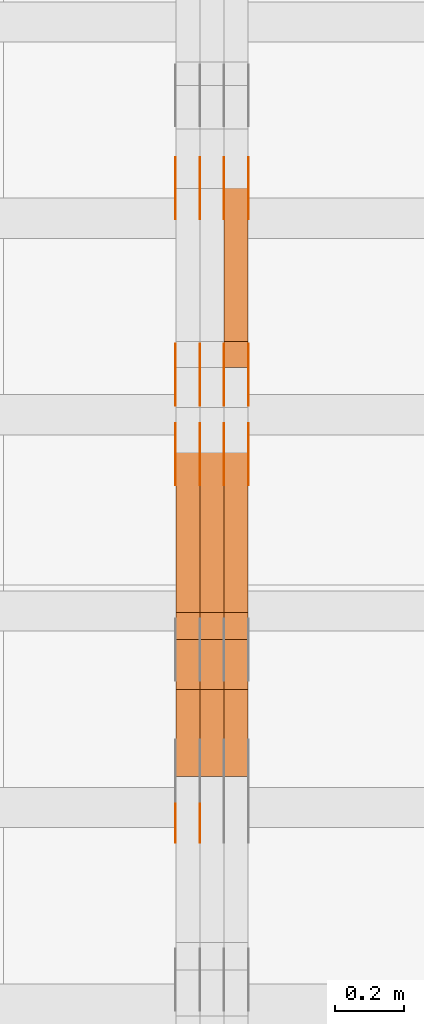
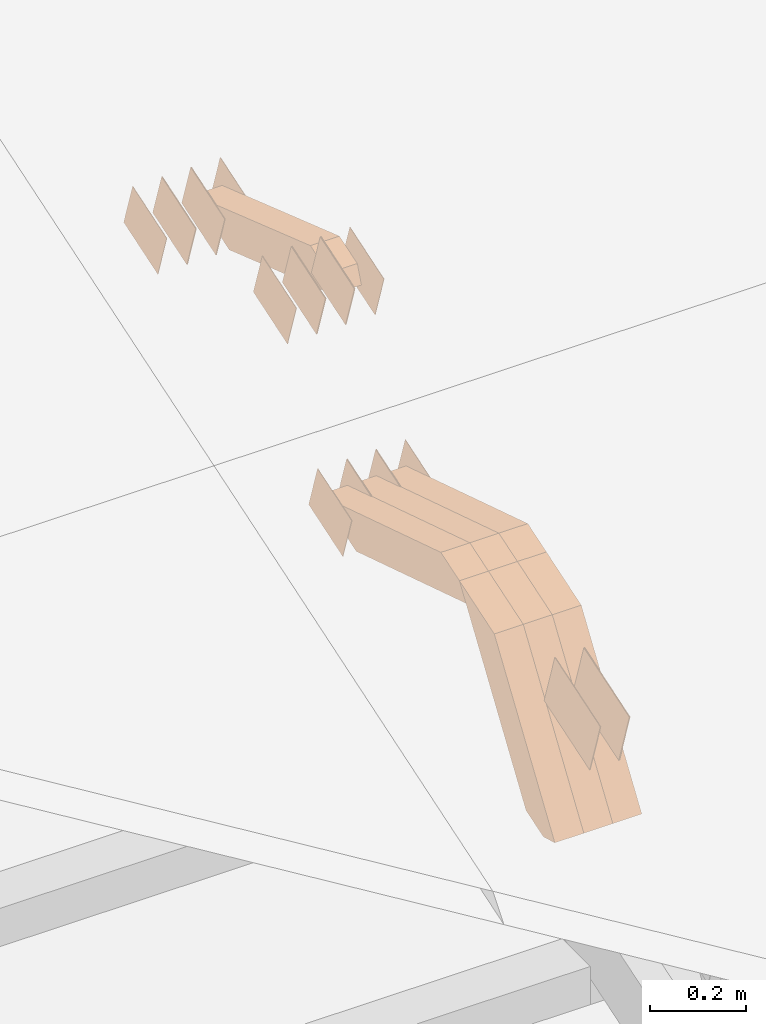
# One storey, part 250 of 385: 28 proxies.
"""IFC2X3 building model written with IfcOpenShell, lengths in millimetres."""

from ifc_helpers import new_model, entity, si_unit, converted_unit, derived_unit, direction, frame, origin, place, context, subcontext, project, spatial, polyline, outline, extrude, source, transform, mapped, material, type_object, type_shapes, element, save


model = new_model("IFC2X3")

# Units and contexts
model_context = context("Model", 3, precision=0.01, world=origin(), true_north=direction((6.12303176911189e-17, 1.0)))
body_context = subcontext(model_context, "Body", "Model", "MODEL_VIEW")
ifc_project = project(units=[si_unit("LENGTHUNIT", "METRE", prefix="MILLI"), si_unit("AREAUNIT", "SQUARE_METRE"), si_unit("VOLUMEUNIT", "CUBIC_METRE"), converted_unit("PLANEANGLEUNIT", "DEGREE", entity("IfcRatioMeasure", 0.0174532925199433), si_unit("PLANEANGLEUNIT", "RADIAN"), dimensions=[0, 0, 0, 0, 0, 0, 0]), si_unit("MASSUNIT", "GRAM", prefix="KILO"), derived_unit("MASSDENSITYUNIT", [(si_unit("MASSUNIT", "GRAM", prefix="KILO"), 1), (si_unit("LENGTHUNIT", "METRE"), -3)]), si_unit("TIMEUNIT", "SECOND"), si_unit("FREQUENCYUNIT", "HERTZ"), si_unit("THERMODYNAMICTEMPERATUREUNIT", "DEGREE_CELSIUS"), derived_unit("THERMALTRANSMITTANCEUNIT", [(si_unit("MASSUNIT", "GRAM", prefix="KILO"), 1), (si_unit("THERMODYNAMICTEMPERATUREUNIT", "KELVIN"), -1), (si_unit("TIMEUNIT", "SECOND"), -3)]), derived_unit("VOLUMETRICFLOWRATEUNIT", [(si_unit("LENGTHUNIT", "METRE"), 3), (si_unit("TIMEUNIT", "SECOND"), -1)]), si_unit("ELECTRICCURRENTUNIT", "AMPERE"), si_unit("ELECTRICVOLTAGEUNIT", "VOLT"), si_unit("POWERUNIT", "WATT"), si_unit("FORCEUNIT", "NEWTON", prefix="KILO"), si_unit("ILLUMINANCEUNIT", "LUX"), si_unit("LUMINOUSFLUXUNIT", "LUMEN"), si_unit("LUMINOUSINTENSITYUNIT", "CANDELA"), derived_unit("USERDEFINED", [(si_unit("MASSUNIT", "GRAM", prefix="KILO"), -1), (si_unit("LENGTHUNIT", "METRE"), -2), (si_unit("TIMEUNIT", "SECOND"), 3), (si_unit("LUMINOUSFLUXUNIT", "LUMEN"), 1)]), derived_unit("LINEARVELOCITYUNIT", [(si_unit("LENGTHUNIT", "METRE"), 1), (si_unit("TIMEUNIT", "SECOND"), -1)]), si_unit("PRESSUREUNIT", "PASCAL"), derived_unit("USERDEFINED", [(si_unit("LENGTHUNIT", "METRE"), -2), (si_unit("MASSUNIT", "GRAM", prefix="KILO"), 1), (si_unit("TIMEUNIT", "SECOND"), -2)])], contexts=[model_context])

# Site, building, storey
site_placement = place(None, origin())
site = spatial("IfcSite", under=ifc_project, at=site_placement, CompositionType="ELEMENT")
building_placement = place(site_placement, origin())
building = spatial("IfcBuilding", under=site, at=building_placement, CompositionType="ELEMENT")
storey_placement = place(building_placement, origin())
storey = spatial("IfcBuildingStorey", under=building, at=storey_placement, Name="Default", CompositionType="ELEMENT", Elevation=0.0)

# Proxies
ifc_material_1 = material(Name="IfcSurfaceStyle #448454")
building_element_proxy_type_1 = type_object("IfcBuildingElementProxyType", PredefinedType="NOTDEFINED", material=ifc_material_1)
shared_shape_1 = source(origin(), body_context, "Body", "SweptSolid", [
    extrude(outline(polyline([(-74.9998754286198, -60.0000016373433), (74.9998605591145, -60.0000016373433), (74.999875428618, 60.0000016373433), (-74.9998605591127, 60.0000016373433), (-74.9998754286198, -60.0000016373433)])), frame((75.0007059026038, 60.000210935219, 0.0), z_axis=(0.0, 0.0, 1.0), x_axis=(-1.0, 0.0, 0.0)), (0.0, 0.0, 1.0), 1.3),
])
type_shapes(building_element_proxy_type_1, [shared_shape_1])
proxy_1_placement = place(building_placement, frame((36386.3, 6760.15341914203, 1372.60670336718), z_axis=(-1.0, 0.0, 0.0), x_axis=(0.0, 0.951056516295124, 0.309016994375039)))
element("IfcBuildingElementProxy", 1, at=proxy_1_placement, inside=storey, type_object=building_element_proxy_type_1, material=ifc_material_1, context=body_context, shape_type="MappedRepresentation", body=[
    mapped(shared_shape_1, transform((0.0, 0.0, 0.0), scale=1.0)),
])
ifc_material_2 = material(Name="IfcSurfaceStyle #448397")
building_element_proxy_type_2 = type_object("IfcBuildingElementProxyType", PredefinedType="NOTDEFINED", material=ifc_material_2)
shared_shape_2 = source(origin(), body_context, "Body", "SweptSolid", [
    extrude(outline(polyline([(-74.9998754286198, -60.0000016373433), (74.9998605591145, -60.0000016373433), (74.999875428618, 60.0000016373433), (-74.9998605591127, 60.0000016373433), (-74.9998754286198, -60.0000016373433)])), frame((75.0007059026038, 60.000210935219, 0.0), z_axis=(0.0, 0.0, 1.0), x_axis=(-1.0, 0.0, 0.0)), (0.0, 0.0, 1.0), 1.3),
])
type_shapes(building_element_proxy_type_2, [shared_shape_2])
proxy_2_placement = place(building_placement, frame((36315.0, 6760.15341914203, 1372.60670336718), z_axis=(-1.0, 0.0, 0.0), x_axis=(0.0, 0.951056516295124, 0.309016994375039)))
element("IfcBuildingElementProxy", 2, at=proxy_2_placement, inside=storey, type_object=building_element_proxy_type_2, material=ifc_material_2, context=body_context, shape_type="MappedRepresentation", body=[
    mapped(shared_shape_2, transform((0.0, 0.0, 0.0), scale=1.0)),
])
ifc_material_3 = material(Name="IfcSurfaceStyle #448340")
building_element_proxy_type_3 = type_object("IfcBuildingElementProxyType", PredefinedType="NOTDEFINED", material=ifc_material_3)
shared_shape_3 = source(origin(), body_context, "Body", "SweptSolid", [
    extrude(outline(polyline([(-74.9998754286198, -60.0000016373433), (74.9998605591145, -60.0000016373433), (74.999875428618, 60.0000016373433), (-74.9998605591127, 60.0000016373433), (-74.9998754286198, -60.0000016373433)])), frame((75.0007059026038, 60.000210935219, 0.0), z_axis=(0.0, 0.0, 1.0), x_axis=(-1.0, 0.0, 0.0)), (0.0, 0.0, 1.0), 1.3),
])
type_shapes(building_element_proxy_type_3, [shared_shape_3])
proxy_3_placement = place(building_placement, frame((36316.3, 6760.15341914203, 1372.60670336718), z_axis=(-1.0, 0.0, 0.0), x_axis=(0.0, 0.951056516295124, 0.309016994375039)))
element("IfcBuildingElementProxy", 3, at=proxy_3_placement, inside=storey, type_object=building_element_proxy_type_3, material=ifc_material_3, context=body_context, shape_type="MappedRepresentation", body=[
    mapped(shared_shape_3, transform((0.0, 0.0, 0.0), scale=1.0)),
])
ifc_material_4 = material(Name="IfcSurfaceStyle #448283")
building_element_proxy_type_4 = type_object("IfcBuildingElementProxyType", PredefinedType="NOTDEFINED", material=ifc_material_4)
shared_shape_4 = source(origin(), body_context, "Body", "SweptSolid", [
    extrude(outline(polyline([(-74.9998754286198, -60.0000016373433), (74.9998605591145, -60.0000016373433), (74.999875428618, 60.0000016373433), (-74.9998605591127, 60.0000016373433), (-74.9998754286198, -60.0000016373433)])), frame((75.0007059026038, 60.000210935219, 0.0), z_axis=(0.0, 0.0, 1.0), x_axis=(-1.0, 0.0, 0.0)), (0.0, 0.0, 1.0), 1.29999999999999),
])
type_shapes(building_element_proxy_type_4, [shared_shape_4])
proxy_4_placement = place(building_placement, frame((36245.0, 6760.15341914203, 1372.60670336718), z_axis=(-1.0, 0.0, 0.0), x_axis=(0.0, 0.951056516295124, 0.309016994375039)))
element("IfcBuildingElementProxy", 4, at=proxy_4_placement, inside=storey, type_object=building_element_proxy_type_4, material=ifc_material_4, context=body_context, shape_type="MappedRepresentation", body=[
    mapped(shared_shape_4, transform((0.0, 0.0, 0.0), scale=1.0)),
])
ifc_material_5 = material(Name="IfcSurfaceStyle #448226")
building_element_proxy_type_5 = type_object("IfcBuildingElementProxyType", PredefinedType="NOTDEFINED", material=ifc_material_5)
shared_shape_5 = source(origin(), body_context, "Body", "SweptSolid", [
    extrude(outline(polyline([(-74.9998754286198, -60.0000016373433), (74.9998605591145, -60.0000016373433), (74.999875428618, 60.0000016373433), (-74.9998605591127, 60.0000016373433), (-74.9998754286198, -60.0000016373433)])), frame((75.0007059026038, 60.000210935219, 0.0), z_axis=(0.0, 0.0, 1.0), x_axis=(-1.0, 0.0, 0.0)), (0.0, 0.0, 1.0), 1.29999999999999),
])
type_shapes(building_element_proxy_type_5, [shared_shape_5])
proxy_5_placement = place(building_placement, frame((36246.3, 6760.15341914203, 1372.60670336718), z_axis=(-1.0, 0.0, 0.0), x_axis=(0.0, 0.951056516295124, 0.309016994375039)))
element("IfcBuildingElementProxy", 5, at=proxy_5_placement, inside=storey, type_object=building_element_proxy_type_5, material=ifc_material_5, context=body_context, shape_type="MappedRepresentation", body=[
    mapped(shared_shape_5, transform((0.0, 0.0, 0.0), scale=1.0)),
])
ifc_material_6 = material(Name="IfcSurfaceStyle #448169")
building_element_proxy_type_6 = type_object("IfcBuildingElementProxyType", PredefinedType="NOTDEFINED", material=ifc_material_6)
shared_shape_6 = source(origin(), body_context, "Body", "SweptSolid", [
    extrude(outline(polyline([(-74.9998754286198, -60.0000016373433), (74.9998605591145, -60.0000016373433), (74.999875428618, 60.0000016373433), (-74.9998605591127, 60.0000016373433), (-74.9998754286198, -60.0000016373433)])), frame((75.0007059026038, 60.000210935219, 0.0), z_axis=(0.0, 0.0, 1.0), x_axis=(-1.0, 0.0, 0.0)), (0.0, 0.0, 1.0), 1.29999999999999),
])
type_shapes(building_element_proxy_type_6, [shared_shape_6])
proxy_6_placement = place(building_placement, frame((36175.0, 6760.15341914203, 1372.60670336718), z_axis=(-1.0, 0.0, 0.0), x_axis=(0.0, 0.951056516295124, 0.309016994375039)))
element("IfcBuildingElementProxy", 6, at=proxy_6_placement, inside=storey, type_object=building_element_proxy_type_6, material=ifc_material_6, context=body_context, shape_type="MappedRepresentation", body=[
    mapped(shared_shape_6, transform((0.0, 0.0, 0.0), scale=1.0)),
])
ifc_material_7 = material(Name="IfcSurfaceStyle #442298")
building_element_proxy_type_7 = type_object("IfcBuildingElementProxyType", PredefinedType="NOTDEFINED", material=ifc_material_7)
shared_shape_7 = source(origin(), body_context, "Body", "SweptSolid", [
    extrude(outline(polyline([(-74.9998801438441, -60.0000306612856), (74.9998747047876, -60.0000306612856), (74.9998707133936, 60.0000306612856), (-74.9998652743371, 60.0000306612856), (-74.9998801438441, -60.0000306612856)])), frame((75.0000206139493, 60.0000306612856, 0.0), z_axis=(0.0, 0.0, 1.0), x_axis=(-1.0, 0.0, 0.0)), (0.0, 0.0, 1.0), 1.3),
])
type_shapes(building_element_proxy_type_7, [shared_shape_7])
proxy_7_placement = place(building_placement, frame((36386.3, 5987.08381858242, 1121.42116774683), z_axis=(-1.0, 0.0, 0.0), x_axis=(0.0, 0.951056516295124, 0.309016994375039)))
element("IfcBuildingElementProxy", 7, at=proxy_7_placement, inside=storey, type_object=building_element_proxy_type_7, material=ifc_material_7, context=body_context, shape_type="MappedRepresentation", body=[
    mapped(shared_shape_7, transform((0.0, 0.0, 0.0), scale=1.0)),
])
ifc_material_8 = material(Name="IfcSurfaceStyle #442241")
building_element_proxy_type_8 = type_object("IfcBuildingElementProxyType", PredefinedType="NOTDEFINED", material=ifc_material_8)
shared_shape_8 = source(origin(), body_context, "Body", "SweptSolid", [
    extrude(outline(polyline([(-74.9998801438441, -60.0000306612856), (74.9998747047876, -60.0000306612856), (74.9998707133936, 60.0000306612856), (-74.9998652743371, 60.0000306612856), (-74.9998801438441, -60.0000306612856)])), frame((75.0000206139493, 60.0000306612856, 0.0), z_axis=(0.0, 0.0, 1.0), x_axis=(-1.0, 0.0, 0.0)), (0.0, 0.0, 1.0), 1.3),
])
type_shapes(building_element_proxy_type_8, [shared_shape_8])
proxy_8_placement = place(building_placement, frame((36315.0, 5987.08381858242, 1121.42116774683), z_axis=(-1.0, 0.0, 0.0), x_axis=(0.0, 0.951056516295124, 0.309016994375039)))
element("IfcBuildingElementProxy", 8, at=proxy_8_placement, inside=storey, type_object=building_element_proxy_type_8, material=ifc_material_8, context=body_context, shape_type="MappedRepresentation", body=[
    mapped(shared_shape_8, transform((0.0, 0.0, 0.0), scale=1.0)),
])
ifc_material_9 = material(Name="IfcSurfaceStyle #442184")
building_element_proxy_type_9 = type_object("IfcBuildingElementProxyType", PredefinedType="NOTDEFINED", material=ifc_material_9)
shared_shape_9 = source(origin(), body_context, "Body", "SweptSolid", [
    extrude(outline(polyline([(-74.9998801438441, -60.0000306612856), (74.9998747047876, -60.0000306612856), (74.9998707133936, 60.0000306612856), (-74.9998652743371, 60.0000306612856), (-74.9998801438441, -60.0000306612856)])), frame((75.0000206139493, 60.0000306612856, 0.0), z_axis=(0.0, 0.0, 1.0), x_axis=(-1.0, 0.0, 0.0)), (0.0, 0.0, 1.0), 1.3),
])
type_shapes(building_element_proxy_type_9, [shared_shape_9])
proxy_9_placement = place(building_placement, frame((36316.3, 5987.08381858242, 1121.42116774683), z_axis=(-1.0, 0.0, 0.0), x_axis=(0.0, 0.951056516295124, 0.309016994375039)))
element("IfcBuildingElementProxy", 9, at=proxy_9_placement, inside=storey, type_object=building_element_proxy_type_9, material=ifc_material_9, context=body_context, shape_type="MappedRepresentation", body=[
    mapped(shared_shape_9, transform((0.0, 0.0, 0.0), scale=1.0)),
])
ifc_material_10 = material(Name="IfcSurfaceStyle #442127")
building_element_proxy_type_10 = type_object("IfcBuildingElementProxyType", PredefinedType="NOTDEFINED", material=ifc_material_10)
shared_shape_10 = source(origin(), body_context, "Body", "SweptSolid", [
    extrude(outline(polyline([(-74.9998801438441, -60.0000306612856), (74.9998747047876, -60.0000306612856), (74.9998707133936, 60.0000306612856), (-74.9998652743371, 60.0000306612856), (-74.9998801438441, -60.0000306612856)])), frame((75.0000206139493, 60.0000306612856, 0.0), z_axis=(0.0, 0.0, 1.0), x_axis=(-1.0, 0.0, 0.0)), (0.0, 0.0, 1.0), 1.29999999999999),
])
type_shapes(building_element_proxy_type_10, [shared_shape_10])
proxy_10_placement = place(building_placement, frame((36245.0, 5987.08381858242, 1121.42116774683), z_axis=(-1.0, 0.0, 0.0), x_axis=(0.0, 0.951056516295124, 0.309016994375039)))
element("IfcBuildingElementProxy", 10, at=proxy_10_placement, inside=storey, type_object=building_element_proxy_type_10, material=ifc_material_10, context=body_context, shape_type="MappedRepresentation", body=[
    mapped(shared_shape_10, transform((0.0, 0.0, 0.0), scale=1.0)),
])
ifc_material_11 = material(Name="IfcSurfaceStyle #442070")
building_element_proxy_type_11 = type_object("IfcBuildingElementProxyType", PredefinedType="NOTDEFINED", material=ifc_material_11)
shared_shape_11 = source(origin(), body_context, "Body", "SweptSolid", [
    extrude(outline(polyline([(-74.9998801438441, -60.0000306612856), (74.9998747047876, -60.0000306612856), (74.9998707133936, 60.0000306612856), (-74.9998652743371, 60.0000306612856), (-74.9998801438441, -60.0000306612856)])), frame((75.0000206139493, 60.0000306612856, 0.0), z_axis=(0.0, 0.0, 1.0), x_axis=(-1.0, 0.0, 0.0)), (0.0, 0.0, 1.0), 1.29999999999999),
])
type_shapes(building_element_proxy_type_11, [shared_shape_11])
proxy_11_placement = place(building_placement, frame((36246.3, 5987.08381858242, 1121.42116774683), z_axis=(-1.0, 0.0, 0.0), x_axis=(0.0, 0.951056516295124, 0.309016994375039)))
element("IfcBuildingElementProxy", 11, at=proxy_11_placement, inside=storey, type_object=building_element_proxy_type_11, material=ifc_material_11, context=body_context, shape_type="MappedRepresentation", body=[
    mapped(shared_shape_11, transform((0.0, 0.0, 0.0), scale=1.0)),
])
ifc_material_12 = material(Name="IfcSurfaceStyle #442013")
building_element_proxy_type_12 = type_object("IfcBuildingElementProxyType", PredefinedType="NOTDEFINED", material=ifc_material_12)
shared_shape_12 = source(origin(), body_context, "Body", "SweptSolid", [
    extrude(outline(polyline([(-74.9998801438441, -60.0000306612856), (74.9998747047876, -60.0000306612856), (74.9998707133936, 60.0000306612856), (-74.9998652743371, 60.0000306612856), (-74.9998801438441, -60.0000306612856)])), frame((75.0000206139493, 60.0000306612856, 0.0), z_axis=(0.0, 0.0, 1.0), x_axis=(-1.0, 0.0, 0.0)), (0.0, 0.0, 1.0), 1.29999999999999),
])
type_shapes(building_element_proxy_type_12, [shared_shape_12])
proxy_12_placement = place(building_placement, frame((36175.0, 5987.08381858242, 1121.42116774683), z_axis=(-1.0, 0.0, 0.0), x_axis=(0.0, 0.951056516295124, 0.309016994375039)))
element("IfcBuildingElementProxy", 12, at=proxy_12_placement, inside=storey, type_object=building_element_proxy_type_12, material=ifc_material_12, context=body_context, shape_type="MappedRepresentation", body=[
    mapped(shared_shape_12, transform((0.0, 0.0, 0.0), scale=1.0)),
])
ifc_material_13 = material(Name="IfcSurfaceStyle #437852")
building_element_proxy_type_13 = type_object("IfcBuildingElementProxyType", PredefinedType="NOTDEFINED", material=ifc_material_13)
shared_shape_13 = source(origin(), body_context, "Body", "SweptSolid", [
    extrude(outline(polyline([(-74.9998754286253, -60.0000016373506), (74.999860559109, -60.0000016373506), (74.9998754286235, 60.0000016373506), (-74.9998605591072, 60.0000016373506), (-74.9998754286253, -60.0000016373506)])), frame((75.0001009411744, 60.0000279841752, 0.0), z_axis=(0.0, 0.0, 1.0), x_axis=(-1.0, 0.0, 0.0)), (0.0, 0.0, 1.0), 1.3),
])
type_shapes(building_element_proxy_type_13, [shared_shape_13])
proxy_13_placement = place(building_placement, frame((36386.3, 6218.29662915452, 1523.23574463408), z_axis=(-1.0, 0.0, 0.0), x_axis=(0.0, 0.951056516295154, 0.309016994374948)))
element("IfcBuildingElementProxy", 13, at=proxy_13_placement, inside=storey, type_object=building_element_proxy_type_13, material=ifc_material_13, context=body_context, shape_type="MappedRepresentation", body=[
    mapped(shared_shape_13, transform((0.0, 0.0, 0.0), scale=1.0)),
])
ifc_material_14 = material(Name="IfcSurfaceStyle #437795")
building_element_proxy_type_14 = type_object("IfcBuildingElementProxyType", PredefinedType="NOTDEFINED", material=ifc_material_14)
shared_shape_14 = source(origin(), body_context, "Body", "SweptSolid", [
    extrude(outline(polyline([(-74.9998754286253, -60.0000016373506), (74.999860559109, -60.0000016373506), (74.9998754286235, 60.0000016373506), (-74.9998605591072, 60.0000016373506), (-74.9998754286253, -60.0000016373506)])), frame((75.0001009411744, 60.0000279841752, 0.0), z_axis=(0.0, 0.0, 1.0), x_axis=(-1.0, 0.0, 0.0)), (0.0, 0.0, 1.0), 1.3),
])
type_shapes(building_element_proxy_type_14, [shared_shape_14])
proxy_14_placement = place(building_placement, frame((36315.0, 6218.29662915452, 1523.23574463408), z_axis=(-1.0, 0.0, 0.0), x_axis=(0.0, 0.951056516295154, 0.309016994374948)))
element("IfcBuildingElementProxy", 14, at=proxy_14_placement, inside=storey, type_object=building_element_proxy_type_14, material=ifc_material_14, context=body_context, shape_type="MappedRepresentation", body=[
    mapped(shared_shape_14, transform((0.0, 0.0, 0.0), scale=1.0)),
])
ifc_material_15 = material(Name="IfcSurfaceStyle #437738")
building_element_proxy_type_15 = type_object("IfcBuildingElementProxyType", PredefinedType="NOTDEFINED", material=ifc_material_15)
shared_shape_15 = source(origin(), body_context, "Body", "SweptSolid", [
    extrude(outline(polyline([(-74.9998754286253, -60.0000016373506), (74.999860559109, -60.0000016373506), (74.9998754286235, 60.0000016373506), (-74.9998605591072, 60.0000016373506), (-74.9998754286253, -60.0000016373506)])), frame((75.0001009411744, 60.0000279841752, 0.0), z_axis=(0.0, 0.0, 1.0), x_axis=(-1.0, 0.0, 0.0)), (0.0, 0.0, 1.0), 1.3),
])
type_shapes(building_element_proxy_type_15, [shared_shape_15])
proxy_15_placement = place(building_placement, frame((36316.3, 6218.29662915452, 1523.23574463408), z_axis=(-1.0, 0.0, 0.0), x_axis=(0.0, 0.951056516295154, 0.309016994374948)))
element("IfcBuildingElementProxy", 15, at=proxy_15_placement, inside=storey, type_object=building_element_proxy_type_15, material=ifc_material_15, context=body_context, shape_type="MappedRepresentation", body=[
    mapped(shared_shape_15, transform((0.0, 0.0, 0.0), scale=1.0)),
])
ifc_material_16 = material(Name="IfcSurfaceStyle #437681")
building_element_proxy_type_16 = type_object("IfcBuildingElementProxyType", PredefinedType="NOTDEFINED", material=ifc_material_16)
shared_shape_16 = source(origin(), body_context, "Body", "SweptSolid", [
    extrude(outline(polyline([(-74.9998754286253, -60.0000016373506), (74.999860559109, -60.0000016373506), (74.9998754286235, 60.0000016373506), (-74.9998605591072, 60.0000016373506), (-74.9998754286253, -60.0000016373506)])), frame((75.0001009411744, 60.0000279841752, 0.0), z_axis=(0.0, 0.0, 1.0), x_axis=(-1.0, 0.0, 0.0)), (0.0, 0.0, 1.0), 1.29999999999999),
])
type_shapes(building_element_proxy_type_16, [shared_shape_16])
proxy_16_placement = place(building_placement, frame((36245.0, 6218.29662915452, 1523.23574463408), z_axis=(-1.0, 0.0, 0.0), x_axis=(0.0, 0.951056516295154, 0.309016994374948)))
element("IfcBuildingElementProxy", 16, at=proxy_16_placement, inside=storey, type_object=building_element_proxy_type_16, material=ifc_material_16, context=body_context, shape_type="MappedRepresentation", body=[
    mapped(shared_shape_16, transform((0.0, 0.0, 0.0), scale=1.0)),
])
ifc_material_17 = material(Name="IfcSurfaceStyle #437624")
building_element_proxy_type_17 = type_object("IfcBuildingElementProxyType", PredefinedType="NOTDEFINED", material=ifc_material_17)
shared_shape_17 = source(origin(), body_context, "Body", "SweptSolid", [
    extrude(outline(polyline([(-74.9998754286253, -60.0000016373506), (74.999860559109, -60.0000016373506), (74.9998754286235, 60.0000016373506), (-74.9998605591072, 60.0000016373506), (-74.9998754286253, -60.0000016373506)])), frame((75.0001009411744, 60.0000279841752, 0.0), z_axis=(0.0, 0.0, 1.0), x_axis=(-1.0, 0.0, 0.0)), (0.0, 0.0, 1.0), 1.29999999999999),
])
type_shapes(building_element_proxy_type_17, [shared_shape_17])
proxy_17_placement = place(building_placement, frame((36246.3, 6218.29662915452, 1523.23574463408), z_axis=(-1.0, 0.0, 0.0), x_axis=(0.0, 0.951056516295154, 0.309016994374948)))
element("IfcBuildingElementProxy", 17, at=proxy_17_placement, inside=storey, type_object=building_element_proxy_type_17, material=ifc_material_17, context=body_context, shape_type="MappedRepresentation", body=[
    mapped(shared_shape_17, transform((0.0, 0.0, 0.0), scale=1.0)),
])
ifc_material_18 = material(Name="IfcSurfaceStyle #437567")
building_element_proxy_type_18 = type_object("IfcBuildingElementProxyType", PredefinedType="NOTDEFINED", material=ifc_material_18)
shared_shape_18 = source(origin(), body_context, "Body", "SweptSolid", [
    extrude(outline(polyline([(-74.9998754286253, -60.0000016373506), (74.999860559109, -60.0000016373506), (74.9998754286235, 60.0000016373506), (-74.9998605591072, 60.0000016373506), (-74.9998754286253, -60.0000016373506)])), frame((75.0001009411744, 60.0000279841752, 0.0), z_axis=(0.0, 0.0, 1.0), x_axis=(-1.0, 0.0, 0.0)), (0.0, 0.0, 1.0), 1.29999999999999),
])
type_shapes(building_element_proxy_type_18, [shared_shape_18])
proxy_18_placement = place(building_placement, frame((36175.0, 6218.29662915452, 1523.23574463408), z_axis=(-1.0, 0.0, 0.0), x_axis=(0.0, 0.951056516295154, 0.309016994374948)))
element("IfcBuildingElementProxy", 18, at=proxy_18_placement, inside=storey, type_object=building_element_proxy_type_18, material=ifc_material_18, context=body_context, shape_type="MappedRepresentation", body=[
    mapped(shared_shape_18, transform((0.0, 0.0, 0.0), scale=1.0)),
])
ifc_material_19 = material(Name="IfcSurfaceStyle #433235")
building_element_proxy_type_19 = type_object("IfcBuildingElementProxyType", PredefinedType="NOTDEFINED", material=ifc_material_19)
shared_shape_19 = source(origin(), body_context, "Body", "SweptSolid", [
    extrude(outline(polyline([(-99.9996257846169, -71.999973710258), (100.000009625089, -71.999973710258), (99.9996257846187, 71.999973710258), (-100.000009625091, 71.999973710258), (-99.9996257846169, -71.999973710258)])), frame((100.000083496635, 72.0000008245779, 0.0), z_axis=(0.0, 0.0, 1.0), x_axis=(-1.0, 0.0, 0.0)), (0.0, 0.0, 1.0), 1.29999999999998),
])
type_shapes(building_element_proxy_type_19, [shared_shape_19])
proxy_19_placement = place(building_placement, frame((36245.0, 4947.73195917316, 1225.53937157357), z_axis=(-1.0, 0.0, 0.0), x_axis=(0.0, 0.951056516295154, 0.309016994374948)))
element("IfcBuildingElementProxy", 19, at=proxy_19_placement, inside=storey, type_object=building_element_proxy_type_19, material=ifc_material_19, context=body_context, shape_type="MappedRepresentation", body=[
    mapped(shared_shape_19, transform((0.0, 0.0, 0.0), scale=1.0)),
])
ifc_material_20 = material(Name="IfcSurfaceStyle #433178")
building_element_proxy_type_20 = type_object("IfcBuildingElementProxyType", PredefinedType="NOTDEFINED", material=ifc_material_20)
shared_shape_20 = source(origin(), body_context, "Body", "SweptSolid", [
    extrude(outline(polyline([(-99.9996257846169, -71.999973710258), (100.000009625089, -71.999973710258), (99.9996257846187, 71.999973710258), (-100.000009625091, 71.999973710258), (-99.9996257846169, -71.999973710258)])), frame((100.000083496635, 72.0000008245779, 0.0), z_axis=(0.0, 0.0, 1.0), x_axis=(-1.0, 0.0, 0.0)), (0.0, 0.0, 1.0), 1.29999999999998),
])
type_shapes(building_element_proxy_type_20, [shared_shape_20])
proxy_20_placement = place(building_placement, frame((36246.3, 4947.73195917316, 1225.53937157357), z_axis=(-1.0, 0.0, 0.0), x_axis=(0.0, 0.951056516295154, 0.309016994374948)))
element("IfcBuildingElementProxy", 20, at=proxy_20_placement, inside=storey, type_object=building_element_proxy_type_20, material=ifc_material_20, context=body_context, shape_type="MappedRepresentation", body=[
    mapped(shared_shape_20, transform((0.0, 0.0, 0.0), scale=1.0)),
])
ifc_material_21 = material(Name="IfcSurfaceStyle #433121")
building_element_proxy_type_21 = type_object("IfcBuildingElementProxyType", PredefinedType="NOTDEFINED", material=ifc_material_21)
shared_shape_21 = source(origin(), body_context, "Body", "SweptSolid", [
    extrude(outline(polyline([(-99.9996257846169, -71.999973710258), (100.000009625089, -71.999973710258), (99.9996257846187, 71.999973710258), (-100.000009625091, 71.999973710258), (-99.9996257846169, -71.999973710258)])), frame((100.000083496635, 72.0000008245779, 0.0), z_axis=(0.0, 0.0, 1.0), x_axis=(-1.0, 0.0, 0.0)), (0.0, 0.0, 1.0), 1.29999999999999),
])
type_shapes(building_element_proxy_type_21, [shared_shape_21])
proxy_21_placement = place(building_placement, frame((36175.0, 4947.73195917316, 1225.53937157357), z_axis=(-1.0, 0.0, 0.0), x_axis=(0.0, 0.951056516295154, 0.309016994374948)))
element("IfcBuildingElementProxy", 21, at=proxy_21_placement, inside=storey, type_object=building_element_proxy_type_21, material=ifc_material_21, context=body_context, shape_type="MappedRepresentation", body=[
    mapped(shared_shape_21, transform((0.0, 0.0, 0.0), scale=1.0)),
])
ifc_material_22 = material(Name="IfcSurfaceStyle #424856")
building_element_proxy_type_22 = type_object("IfcBuildingElementProxyType", Name="T1-W19 424854", PredefinedType="NOTDEFINED", material=ifc_material_22)
shared_shape_22 = source(origin(), body_context, "Body", "SweptSolid", [
    extrude(outline(polyline([(-234.986199656822, -47.5000587840676), (221.224626701627, -47.5000587840676), (219.29748584664, -9.04449542012076e-05), (156.014457007826, 47.5001040065446), (-361.550369899272, 47.5001040065447), (-234.986199656822, -47.5000587840676)])), frame((221.224626701627, 47.5001108598228, 0.0), z_axis=(0.0, 0.0, 1.0), x_axis=(-1.0, 0.0, 0.0)), (0.0, 0.0, 1.0), 70.0),
])
type_shapes(building_element_proxy_type_22, [shared_shape_22])
proxy_22_placement = place(building_placement, frame((36385.0, 6342.4042570111, 1541.63383639481), z_axis=(-1.0, 0.0, 0.0), x_axis=(0.0, 0.9461301511345, -0.323786561046329)))
element("IfcBuildingElementProxy", 22, at=proxy_22_placement, inside=storey, type_object=building_element_proxy_type_22, material=ifc_material_22, Name="T1-W19", context=body_context, shape_type="MappedRepresentation", body=[
    mapped(shared_shape_22, transform((0.0, 0.0, 0.0), scale=1.0)),
])
ifc_material_23 = material(Name="IfcSurfaceStyle #424064")
building_element_proxy_type_23 = type_object("IfcBuildingElementProxyType", Name="T1-W15 424062", PredefinedType="NOTDEFINED", material=ifc_material_23)
shared_shape_23 = source(origin(), body_context, "Body", "SweptSolid", [
    extrude(outline(polyline([(-243.398341390642, -47.5000170814535), (237.775741169608, -47.5000170814535), (224.054017709933, 0.000127777485579883), (157.692261395711, 47.4999531927108), (-376.12367888461, 47.4999531927107), (-243.398341390642, -47.5000170814535)])), frame((237.77637044506, 47.5003404768297, 0.0), z_axis=(0.0, 0.0, 1.0), x_axis=(-1.0, 0.0, 0.0)), (0.0, 0.0, 1.0), 70.0),
])
type_shapes(building_element_proxy_type_23, [shared_shape_23])
proxy_23_placement = place(building_placement, frame((36385.0, 5540.23242178142, 1288.84274826279), z_axis=(-1.0, 0.0, 0.0), x_axis=(0.0, 0.95322291386448, -0.302268219440466)))
element("IfcBuildingElementProxy", 23, at=proxy_23_placement, inside=storey, type_object=building_element_proxy_type_23, material=ifc_material_23, Name="T1-W15", context=body_context, shape_type="MappedRepresentation", body=[
    mapped(shared_shape_23, transform((0.0, 0.0, 0.0), scale=1.0)),
])
ifc_material_24 = material(Name="IfcSurfaceStyle #423998")
building_element_proxy_type_24 = type_object("IfcBuildingElementProxyType", Name="T1-W15 423996", PredefinedType="NOTDEFINED", material=ifc_material_24)
shared_shape_24 = source(origin(), body_context, "Body", "SweptSolid", [
    extrude(outline(polyline([(-243.398341390642, -47.5000170814535), (237.775741169608, -47.5000170814535), (224.054017709933, 0.000127777485579883), (157.692261395711, 47.4999531927108), (-376.12367888461, 47.4999531927107), (-243.398341390642, -47.5000170814535)])), frame((237.77637044506, 47.5003404768297, 0.0), z_axis=(0.0, 0.0, 1.0), x_axis=(-1.0, 0.0, 0.0)), (0.0, 0.0, 1.0), 70.0),
])
type_shapes(building_element_proxy_type_24, [shared_shape_24])
proxy_24_placement = place(building_placement, frame((36315.0, 5540.23242178142, 1288.84274826279), z_axis=(-1.0, 0.0, 0.0), x_axis=(0.0, 0.95322291386448, -0.302268219440466)))
element("IfcBuildingElementProxy", 24, at=proxy_24_placement, inside=storey, type_object=building_element_proxy_type_24, material=ifc_material_24, Name="T1-W15", context=body_context, shape_type="MappedRepresentation", body=[
    mapped(shared_shape_24, transform((0.0, 0.0, 0.0), scale=1.0)),
])
ifc_material_25 = material(Name="IfcSurfaceStyle #423932")
building_element_proxy_type_25 = type_object("IfcBuildingElementProxyType", Name="T1-W15 423930", PredefinedType="NOTDEFINED", material=ifc_material_25)
shared_shape_25 = source(origin(), body_context, "Body", "SweptSolid", [
    extrude(outline(polyline([(-243.398341390642, -47.5000170814535), (237.775741169608, -47.5000170814535), (224.054017709933, 0.000127777485579883), (157.692261395711, 47.4999531927108), (-376.12367888461, 47.4999531927107), (-243.398341390642, -47.5000170814535)])), frame((237.77637044506, 47.5003404768297, 0.0), z_axis=(0.0, 0.0, 1.0), x_axis=(-1.0, 0.0, 0.0)), (0.0, 0.0, 1.0), 70.0),
])
type_shapes(building_element_proxy_type_25, [shared_shape_25])
proxy_25_placement = place(building_placement, frame((36245.0, 5540.23242178142, 1288.84274826279), z_axis=(-1.0, 0.0, 0.0), x_axis=(0.0, 0.95322291386448, -0.302268219440466)))
element("IfcBuildingElementProxy", 25, at=proxy_25_placement, inside=storey, type_object=building_element_proxy_type_25, material=ifc_material_25, Name="T1-W15", context=body_context, shape_type="MappedRepresentation", body=[
    mapped(shared_shape_25, transform((0.0, 0.0, 0.0), scale=1.0)),
])
ifc_material_26 = material(Name="IfcSurfaceStyle #423668")
building_element_proxy_type_26 = type_object("IfcBuildingElementProxyType", Name="T1-W22 423666", PredefinedType="NOTDEFINED", material=ifc_material_26)
shared_shape_26 = source(origin(), body_context, "Body", "SweptSolid", [
    extrude(outline(polyline([(-351.940486061686, -47.5005995570677), (149.451602529695, -47.5005995570676), (209.614029773051, 0.000108554198836676), (224.491670779786, 47.5010029530092), (-231.616817020846, 47.5000876069273), (-351.940486061686, -47.5005995570677)])), frame((224.491766107217, 47.5005524294596, 0.0), z_axis=(0.0, 0.0, 1.0), x_axis=(-1.0, 2.00686044286885e-06, 0.0)), (0.0, 0.0, 1.0), 70.0),
])
type_shapes(building_element_proxy_type_26, [shared_shape_26])
proxy_26_placement = place(building_placement, frame((36385.0, 5140.03125, 812.615600585936), z_axis=(-1.0, 0.0, 0.0), x_axis=(0.0, 0.554956576676696, 0.831879316970486)))
element("IfcBuildingElementProxy", 26, at=proxy_26_placement, inside=storey, type_object=building_element_proxy_type_26, material=ifc_material_26, Name="T1-W22", context=body_context, shape_type="MappedRepresentation", body=[
    mapped(shared_shape_26, transform((0.0, 0.0, 0.0), scale=1.0)),
])
ifc_material_27 = material(Name="IfcSurfaceStyle #423602")
building_element_proxy_type_27 = type_object("IfcBuildingElementProxyType", Name="T1-W22 423600", PredefinedType="NOTDEFINED", material=ifc_material_27)
shared_shape_27 = source(origin(), body_context, "Body", "SweptSolid", [
    extrude(outline(polyline([(-351.940486061686, -47.5005995570677), (149.451602529695, -47.5005995570676), (209.614029773051, 0.000108554198836676), (224.491670779786, 47.5010029530092), (-231.616817020846, 47.5000876069273), (-351.940486061686, -47.5005995570677)])), frame((224.491766107217, 47.5005524294596, 0.0), z_axis=(0.0, 0.0, 1.0), x_axis=(-1.0, 2.00686044286885e-06, 0.0)), (0.0, 0.0, 1.0), 70.0),
])
type_shapes(building_element_proxy_type_27, [shared_shape_27])
proxy_27_placement = place(building_placement, frame((36315.0, 5140.03125, 812.615600585936), z_axis=(-1.0, 0.0, 0.0), x_axis=(0.0, 0.554956576676696, 0.831879316970486)))
element("IfcBuildingElementProxy", 27, at=proxy_27_placement, inside=storey, type_object=building_element_proxy_type_27, material=ifc_material_27, Name="T1-W22", context=body_context, shape_type="MappedRepresentation", body=[
    mapped(shared_shape_27, transform((0.0, 0.0, 0.0), scale=1.0)),
])
ifc_material_28 = material(Name="IfcSurfaceStyle #423536")
building_element_proxy_type_28 = type_object("IfcBuildingElementProxyType", Name="T1-W22 423534", PredefinedType="NOTDEFINED", material=ifc_material_28)
shared_shape_28 = source(origin(), body_context, "Body", "SweptSolid", [
    extrude(outline(polyline([(-351.940486061686, -47.5005995570677), (149.451602529695, -47.5005995570676), (209.614029773051, 0.000108554198836676), (224.491670779786, 47.5010029530092), (-231.616817020846, 47.5000876069273), (-351.940486061686, -47.5005995570677)])), frame((224.491766107217, 47.5005524294596, 0.0), z_axis=(0.0, 0.0, 1.0), x_axis=(-1.0, 2.00686044286885e-06, 0.0)), (0.0, 0.0, 1.0), 70.0),
])
type_shapes(building_element_proxy_type_28, [shared_shape_28])
proxy_28_placement = place(building_placement, frame((36245.0, 5140.03125, 812.615600585936), z_axis=(-1.0, 0.0, 0.0), x_axis=(0.0, 0.554956576676696, 0.831879316970486)))
element("IfcBuildingElementProxy", 28, at=proxy_28_placement, inside=storey, type_object=building_element_proxy_type_28, material=ifc_material_28, Name="T1-W22", context=body_context, shape_type="MappedRepresentation", body=[
    mapped(shared_shape_28, transform((0.0, 0.0, 0.0), scale=1.0)),
])

save(model, "model.ifc")
